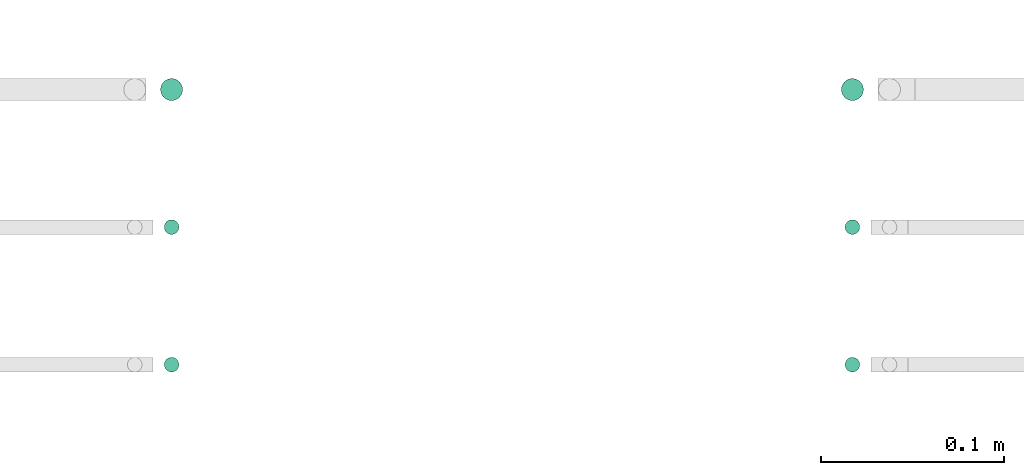
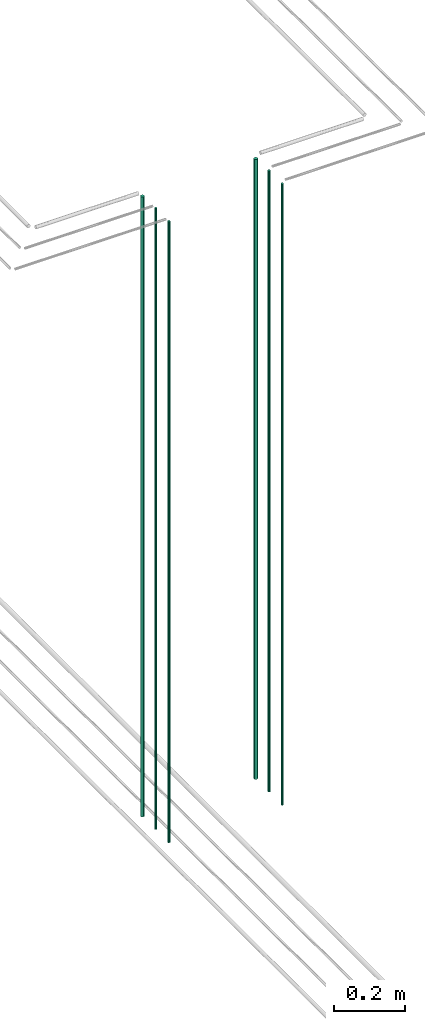
# One storey, part 4 of 331: 6 flow segments.
"""IFC2X3 building model written with IfcOpenShell, lengths in millimetres."""

from ifc_helpers import new_model, entity, si_unit, converted_unit, derived_unit, direction, frame, frame_2d, origin, origin_2d_with_axis, place, context, subcontext, project, spatial, circle, extrude, type_object, element, save


model = new_model("IFC2X3")

# Units and contexts
model_context = context("Model", 3, precision=0.01, world=origin(), true_north=direction((6.12303176911189e-17, 1.0)))
body_context = subcontext(model_context, "Body", "Model", "MODEL_VIEW")
ifc_project = project(units=[si_unit("LENGTHUNIT", "METRE", prefix="MILLI"), si_unit("AREAUNIT", "SQUARE_METRE"), si_unit("VOLUMEUNIT", "CUBIC_METRE"), converted_unit("PLANEANGLEUNIT", "DEGREE", entity("IfcRatioMeasure", 0.0174532925199433), si_unit("PLANEANGLEUNIT", "RADIAN"), dimensions=[0, 0, 0, 0, 0, 0, 0]), si_unit("MASSUNIT", "GRAM", prefix="KILO"), derived_unit("MASSDENSITYUNIT", [(si_unit("MASSUNIT", "GRAM", prefix="KILO"), 1), (si_unit("LENGTHUNIT", "METRE"), -3)]), derived_unit("MOMENTOFINERTIAUNIT", [(si_unit("LENGTHUNIT", "METRE"), 4)]), si_unit("TIMEUNIT", "SECOND"), si_unit("FREQUENCYUNIT", "HERTZ"), si_unit("THERMODYNAMICTEMPERATUREUNIT", "DEGREE_CELSIUS"), derived_unit("THERMALTRANSMITTANCEUNIT", [(si_unit("MASSUNIT", "GRAM", prefix="KILO"), 1), (si_unit("THERMODYNAMICTEMPERATUREUNIT", "KELVIN"), -1), (si_unit("TIMEUNIT", "SECOND"), -3)]), derived_unit("VOLUMETRICFLOWRATEUNIT", [(si_unit("LENGTHUNIT", "METRE"), 3), (si_unit("TIMEUNIT", "SECOND"), -1)]), derived_unit("MASSFLOWRATEUNIT", [(si_unit("MASSUNIT", "GRAM", prefix="KILO"), 1), (si_unit("TIMEUNIT", "SECOND"), -1)]), derived_unit("ROTATIONALFREQUENCYUNIT", [(si_unit("TIMEUNIT", "SECOND"), -1)]), si_unit("ELECTRICCURRENTUNIT", "AMPERE"), si_unit("ELECTRICVOLTAGEUNIT", "VOLT"), si_unit("POWERUNIT", "WATT"), si_unit("FORCEUNIT", "NEWTON", prefix="KILO"), si_unit("ILLUMINANCEUNIT", "LUX"), si_unit("LUMINOUSFLUXUNIT", "LUMEN"), si_unit("LUMINOUSINTENSITYUNIT", "CANDELA"), derived_unit("USERDEFINED", [(si_unit("MASSUNIT", "GRAM", prefix="KILO"), -1), (si_unit("LENGTHUNIT", "METRE"), -2), (si_unit("TIMEUNIT", "SECOND"), 3), (si_unit("LUMINOUSFLUXUNIT", "LUMEN"), 1)]), derived_unit("LINEARVELOCITYUNIT", [(si_unit("LENGTHUNIT", "METRE"), 1), (si_unit("TIMEUNIT", "SECOND"), -1)]), si_unit("PRESSUREUNIT", "PASCAL"), derived_unit("USERDEFINED", [(si_unit("LENGTHUNIT", "METRE"), -2), (si_unit("MASSUNIT", "GRAM", prefix="KILO"), 1), (si_unit("TIMEUNIT", "SECOND"), -2)]), derived_unit("LINEARFORCEUNIT", [(si_unit("MASSUNIT", "GRAM", prefix="KILO"), 1), (si_unit("LENGTHUNIT", "METRE"), 1), (si_unit("TIMEUNIT", "SECOND"), -2), (si_unit("LENGTHUNIT", "METRE"), -1)]), derived_unit("PLANARFORCEUNIT", [(si_unit("MASSUNIT", "GRAM", prefix="KILO"), 1), (si_unit("LENGTHUNIT", "METRE"), 1), (si_unit("TIMEUNIT", "SECOND"), -2), (si_unit("LENGTHUNIT", "METRE"), -2)])], contexts=[model_context])

# Site, building, storey
site_placement = place(None, frame((0.0, -0.00077364408347762, 0.0)))
site = spatial("IfcSite", under=ifc_project, at=site_placement, CompositionType="ELEMENT")
building_placement = place(site_placement, origin())
building = spatial("IfcBuilding", under=site, at=building_placement, CompositionType="ELEMENT")
storey_placement = place(building_placement, origin())
storey = spatial("IfcBuildingStorey", under=building, at=storey_placement, CompositionType="ELEMENT", Elevation=0.0)

# Flow segments
pipe_segment_type = type_object("IfcPipeSegmentType", PredefinedType="NOTDEFINED")
flow_segment_1_placement = place(storey_placement, frame((25949.137938892, 1343.89349484305, 12990.0)))
element("IfcFlowSegment", 1, at=flow_segment_1_placement, inside=storey, type_object=pipe_segment_type, context=body_context, shape_type="SweptSolid", body=[
    extrude(circle(Radius=6.0, at=origin_2d_with_axis()), frame((7.59527223591454, 7.59527223591589, 0.0)), (0.0, 0.0, 1.0), 2146.0),
])
flow_segment_2_placement = place(storey_placement, frame((25951.137938892, 1270.89349484385, 12990.0)))
element("IfcFlowSegment", 2, at=flow_segment_2_placement, inside=storey, type_object=pipe_segment_type, context=body_context, shape_type="SweptSolid", body=[
    extrude(circle(Radius=4.0, at=origin_2d_with_axis()), frame((5.59527223591499, 5.5952722359158, 0.0)), (0.0, 0.0, 1.0), 2150.00000000001),
])
flow_segment_3_placement = place(storey_placement, frame((25951.137938892, 1195.89349484327, 12990.0)))
element("IfcFlowSegment", 3, at=flow_segment_3_placement, inside=storey, type_object=pipe_segment_type, context=body_context, shape_type="SweptSolid", body=[
    extrude(circle(Radius=4.0, at=frame_2d((0.0, 1.35358391162299e-13), x_axis=(1.0, 0.0))), frame((5.59527223591499, 5.59527223591594, 0.0)), (0.0, 0.0, 1.0), 2150.00000000001),
])
flow_segment_4_placement = place(storey_placement, frame((25577.9067248322, 1343.89349484309, 12990.0)))
element("IfcFlowSegment", 4, at=flow_segment_4_placement, inside=storey, type_object=pipe_segment_type, context=body_context, shape_type="SweptSolid", body=[
    extrude(circle(Radius=6.0, at=origin_2d_with_axis()), frame((7.59527223591454, 7.59527223591589, 0.0)), (0.0, 0.0, 1.0), 2146.0),
])
flow_segment_5_placement = place(storey_placement, frame((25579.9067248322, 1270.89349484385, 12990.0)))
element("IfcFlowSegment", 5, at=flow_segment_5_placement, inside=storey, type_object=pipe_segment_type, context=body_context, shape_type="SweptSolid", body=[
    extrude(circle(Radius=4.0, at=origin_2d_with_axis()), frame((5.59527223591499, 5.5952722359158, 0.0)), (0.0, 0.0, 1.0), 2150.00000000001),
])
flow_segment_6_placement = place(storey_placement, frame((25579.9067248322, 1195.8934948433, 12990.0)))
element("IfcFlowSegment", 6, at=flow_segment_6_placement, inside=storey, type_object=pipe_segment_type, context=body_context, shape_type="SweptSolid", body=[
    extrude(circle(Radius=4.0, at=origin_2d_with_axis()), frame((5.59527223591499, 5.59527223591607, 0.0)), (0.0, 0.0, 1.0), 2150.00000000001),
])

save(model, "model.ifc")
